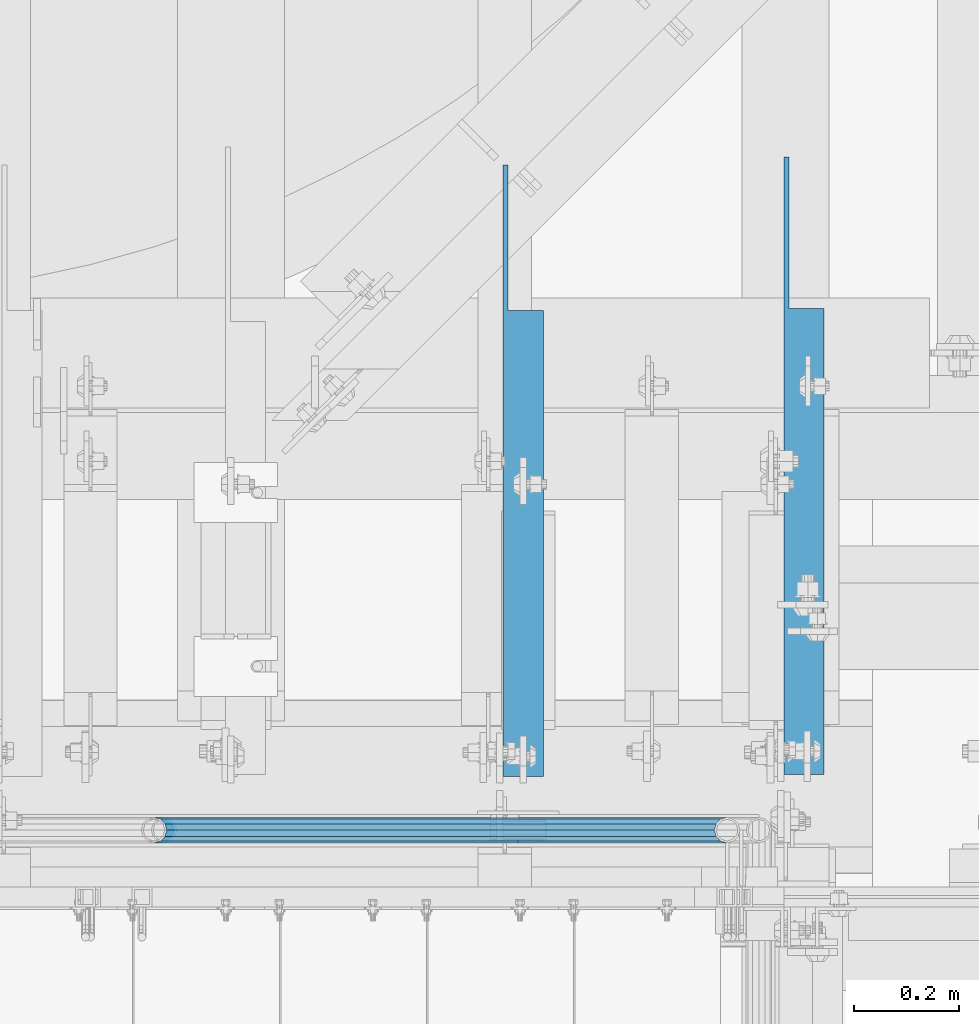
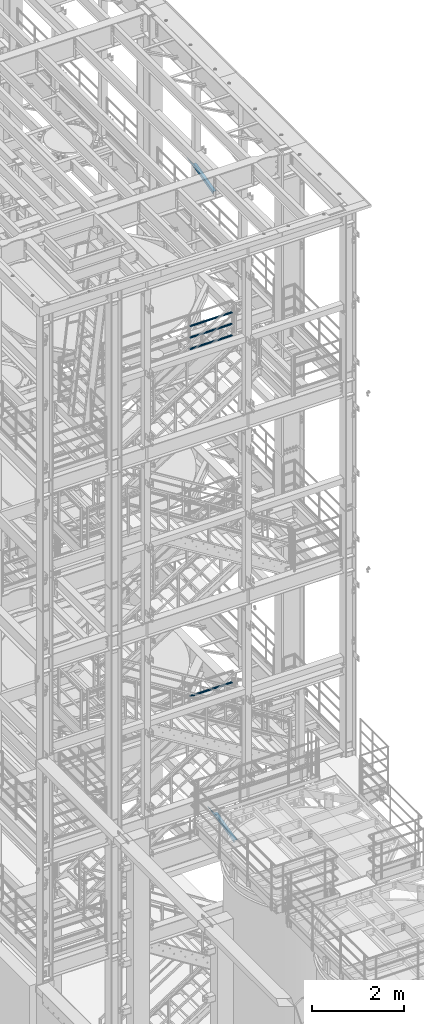
# One storey, part 987 of 1876: 6 beams, 4 elements without a shape of their own.
"""IFC2X3 building model written with IfcOpenShell, lengths in millimetres."""

from ifc_helpers import new_model, si_unit, frame, origin_with_axes, place, context, subcontext, project, spatial, faceted_brep, material, type_object, element, aggregate, save


model = new_model("IFC2X3")

# Units and contexts
model_context = context("Model", 3, precision=1e-05, world=origin_with_axes())
body_context = subcontext(model_context, "Body", "Model", "MODEL_VIEW")
ifc_project = project(units=[si_unit("LENGTHUNIT", "METRE", prefix="MILLI"), si_unit("AREAUNIT", "SQUARE_METRE"), si_unit("VOLUMEUNIT", "CUBIC_METRE"), si_unit("MASSUNIT", "GRAM", prefix="KILO"), si_unit("TIMEUNIT", "SECOND"), si_unit("PLANEANGLEUNIT", "RADIAN"), si_unit("SOLIDANGLEUNIT", "STERADIAN"), si_unit("THERMODYNAMICTEMPERATUREUNIT", "DEGREE_CELSIUS"), si_unit("LUMINOUSINTENSITYUNIT", "LUMEN")], contexts=[model_context])

# Site, building, storey
site_placement = place(None, origin_with_axes())
site = spatial("IfcSite", under=ifc_project, at=site_placement, CompositionType="ELEMENT")
building_placement = place(site_placement, origin_with_axes())
building = spatial("IfcBuilding", under=site, at=building_placement, Name="Undefined", CompositionType="ELEMENT")
storey_placement = place(building_placement, origin_with_axes())
storey = spatial("IfcBuildingStorey", under=building, at=storey_placement, Name="Undefined", CompositionType="ELEMENT", Elevation=0.0)

# Assembly, beam
assembly_1_placement = place(storey_placement, origin_with_axes())
assembly_1 = element("IfcElementAssembly", 1, at=assembly_1_placement, inside=storey, Name="RAIL", AssemblyPlace="NOTDEFINED", PredefinedType="RIGID_FRAME")
ifc_material_1 = material()
beam_type_1 = type_object("IfcBeamType", Name="PIPE1-1/2SCH40", PredefinedType="NOTDEFINED")
beam_1_placement = place(assembly_1_placement, frame((5048.24999996468, -4654.55000114554, 8924.925), z_axis=(0.0, 0.0, -1.0), x_axis=(1.0, 0.0, 0.0)))
beam_1 = element("IfcBeam", 2, at=beam_1_placement, type_object=beam_type_1, material=ifc_material_1, Name="RAIL", ObjectType="PIPE1-1/2SCH40", context=body_context, shape_type="Brep", body=[
    faceted_brep([(0.0, 24.1299999999992, 0.0), (12.0650000000064, 20.8971929933177, -12.0649999999987), (12.0650000000064, 20.8971929933177, 12.0649999999987), (12.0650000000064, -20.8971929933177, 12.0649999999987), (12.0650000000064, -20.8971929933177, -12.0649999999987), (0.0, -24.1299999999992, 0.0), (20.8971929933249, -12.0650000000005, 20.8971929933177), (20.8971929933249, -12.0650000000005, 15.8661214311796), (15.2545715621445, -17.7076214311801, 10.2235000000001), (12.5151929933249, -20.4470000000001, 0.0), (15.2545715621445, -17.7076214311801, -10.2235000000001), (20.8971929933249, -12.0650000000005, -15.8661214311796), (20.8971929933249, -12.0650000000005, -20.8971929933177), (24.1300000000063, 0.0, -20.4470000000001), (24.1300000000063, 0.0, -24.130000000001), (21.3906214311868, -10.2235000000001, -17.7076214311819), (21.3906214311868, 10.2235000000001, -17.7076214311819), (20.8971929933249, 12.0650000000005, -15.8661214311796), (20.8971929933249, 12.0650000000005, -20.8971929933177), (15.2545715621445, 17.7076214311801, -10.2235000000001), (12.5151929933249, 20.4470000000001, 0.0), (15.2545715621445, 17.7076214311801, 10.2235000000001), (20.8971929933249, 12.0650000000005, 15.8661214311796), (20.8971929933249, 12.0650000000005, 20.8971929933177), (21.3906214311868, 10.2235000000001, 17.7076214311819), (24.1300000000064, 0.0, 20.4470000000001), (24.1300000000064, 0.0, 24.130000000001), (21.3906214311868, -10.2235000000001, 17.7076214311819), (1089.02499998822, 24.1300000000001, 0.0), (1076.95999998821, 20.8971929933186, -12.0650000000005), (1068.12780699489, 12.0649999999996, -20.8971929933177), (1089.02499998821, -24.1299999999865, 0.0), (1076.95999998821, -20.8971929933186, -12.0650000000005), (1076.95999998821, -20.8971929933186, 12.0650000000005), (1068.12780699489, -12.0649999999996, 20.8971929933177), (1068.12780699489, -12.0649999999996, -20.8971929933177), (1064.89499998821, 0.0, -24.1299999999992), (1067.63437855703, 10.2235000000001, -17.7076214311801), (1064.89499998821, 0.0, -20.4470000000001), (1068.12780699489, 12.0650000000132, -15.8661214311669), (1068.12780699489, -12.064999999986, -15.8661214311942), (1067.63437855703, -10.2235000000001, -17.7076214311801), (1073.77042842609, -17.7076214311801, -10.2235000000001), (1076.50980699491, -20.4470000000001, 0.0), (1073.77042842609, -17.7076214311801, 10.2235000000001), (1068.12780699489, -12.064999999986, 15.8661214311942), (1067.63437855703, -10.2235000000001, 17.7076214311801), (1064.89499998821, 0.0, 20.4470000000001), (1064.89499998821, 0.0, 24.1299999999992), (1068.12780699489, 12.0649999999996, 20.8971929933177), (1076.95999998821, 20.8971929933186, 12.0650000000005), (1068.12780699489, 12.0650000000132, 15.8661214311669), (1073.77042842606, 17.7076214311801, 10.2235000000001), (1076.50980699488, 20.4470000000001, 0.0), (1073.77042842606, 17.7076214311801, -10.2235000000001), (1067.63437855703, 10.2235000000001, 17.7076214311801)], [[[0, 1, 2]], [[3, 4, 5]], [[6, 7, 8, 9, 10, 11, 12, 4, 3]], [[13, 14, 12, 11, 15]], [[16, 17, 18, 14, 13]], [[2, 1, 18, 17, 19, 20, 21, 22, 23]], [[23, 22, 24, 25, 26]], [[26, 25, 27, 7, 6]], [[1, 0, 28, 29]], [[18, 1, 29, 30]], [[31, 32, 33]], [[6, 3, 33, 34]], [[3, 5, 31, 33]], [[5, 4, 32, 31]], [[4, 12, 35, 32]], [[12, 14, 36, 35]], [[14, 18, 30, 36]], [[37, 38, 36, 30, 39]], [[40, 35, 36, 38, 41]], [[33, 32, 35, 40, 42, 43, 44, 45, 34]], [[34, 45, 46, 47, 48]], [[26, 6, 34, 48]], [[2, 23, 49, 50]], [[23, 26, 48, 49]], [[0, 2, 50, 28]], [[28, 50, 29]], [[49, 51, 52, 53, 54, 39, 30, 29, 50]], [[48, 47, 55, 51, 49]], [[25, 24, 55, 47]], [[55, 24, 22, 21, 52, 51]], [[21, 20, 53, 52]], [[20, 19, 54, 53]], [[19, 17, 16, 37, 39, 54]], [[16, 13, 38, 37]], [[13, 15, 41, 38]], [[41, 15, 11, 10, 42, 40]], [[10, 9, 43, 42]], [[9, 8, 44, 43]], [[8, 7, 27, 46, 45, 44]], [[27, 25, 47, 46]]]),
])
aggregate(assembly_1, [beam_1])

# Assembly, beams
assembly_2_placement = place(storey_placement, origin_with_axes())
assembly_2 = element("IfcElementAssembly", 3, at=assembly_2_placement, inside=storey, Name="RAIL", AssemblyPlace="NOTDEFINED", PredefinedType="RIGID_FRAME")
beam_2_placement = place(assembly_2_placement, frame((6137.27499995291, -4654.55000114554, 18145.125), z_axis=(0.0, 0.0, 1.0), x_axis=(-1.0, 0.0, 0.0)))
beam_2 = element("IfcBeam", 4, at=beam_2_placement, type_object=beam_type_1, material=ifc_material_1, Name="RAIL", ObjectType="PIPE1-1/2SCH40", context=body_context, shape_type="Brep", body=[
    faceted_brep([(1068.12780699489, -12.0649999999996, 20.8971929933177), (1068.12780699489, -12.064999999986, 15.8661214311942), (1067.63437855703, -10.2235000000001, 17.7076214311801), (1064.89499998821, 0.0, 20.4470000000001), (1064.89499998821, 0.0, 24.1299999999992), (1067.63437855703, 10.2235000000001, 17.7076214311801), (1068.12780699489, 12.0650000000132, 15.8661214311669), (1068.12780699489, 12.0649999999996, 20.8971929933177), (1089.02499998822, 24.1300000000001, 0.0), (1076.95999998821, 20.8971929933186, 12.0650000000005), (1076.95999998821, 20.8971929933186, -12.0650000000005), (1073.77042842606, 17.7076214311801, 10.2235000000001), (1076.50980699488, 20.4470000000001, 0.0), (1073.77042842606, 17.7076214311801, -10.2235000000001), (1068.12780699489, 12.0650000000132, -15.8661214311669), (1068.12780699489, 12.0649999999996, -20.8971929933177), (1067.63437855703, 10.2235000000001, -17.7076214311801), (1064.89499998821, 0.0, -20.4470000000001), (1064.89499998821, 0.0, -24.1299999999992), (1068.12780699489, -12.064999999986, -15.8661214311942), (1068.12780699489, -12.0649999999996, -20.8971929933177), (1067.63437855703, -10.2235000000001, -17.7076214311801), (1089.02499998821, -24.1299999999865, 0.0), (1076.95999998821, -20.8971929933186, -12.0650000000005), (1076.95999998821, -20.8971929933186, 12.0650000000005), (1073.77042842609, -17.7076214311801, -10.2235000000001), (1076.50980699491, -20.4470000000001, 0.0), (1073.77042842609, -17.7076214311801, 10.2235000000001), (12.0650000000064, -20.8971929933177, -12.0649999999987), (20.8971929933249, -12.0650000000005, -20.8971929933177), (0.0, 24.1299999999992, 0.0), (12.0650000000064, 20.8971929933177, -12.0649999999987), (12.0650000000064, 20.8971929933177, 12.0649999999987), (20.8971929933249, 12.0650000000005, 20.8971929933177), (24.1300000000064, 0.0, 24.130000000001), (20.8971929933249, 12.0650000000005, -20.8971929933177), (24.1300000000063, 0.0, -24.130000000001), (24.1300000000063, 0.0, -20.4470000000001), (20.8971929933249, -12.0650000000005, -15.8661214311796), (21.3906214311868, -10.2235000000001, -17.7076214311819), (21.3906214311868, 10.2235000000001, -17.7076214311819), (20.8971929933249, 12.0650000000005, -15.8661214311796), (15.2545715621445, 17.7076214311801, -10.2235000000001), (12.5151929933249, 20.4470000000001, 0.0), (15.2545715621445, 17.7076214311801, 10.2235000000001), (20.8971929933249, 12.0650000000005, 15.8661214311796), (21.3906214311868, 10.2235000000001, 17.7076214311819), (24.1300000000064, 0.0, 20.4470000000001), (21.3906214311868, -10.2235000000001, 17.7076214311819), (20.8971929933249, -12.0650000000005, 15.8661214311796), (20.8971929933249, -12.0650000000005, 20.8971929933177), (12.0650000000064, -20.8971929933177, 12.0649999999987), (0.0, -24.1299999999992, 0.0), (15.2545715621445, -17.7076214311801, 10.2235000000001), (12.5151929933249, -20.4470000000001, 0.0), (15.2545715621445, -17.7076214311801, -10.2235000000001)], [[[0, 1, 2, 3, 4]], [[4, 3, 5, 6, 7]], [[8, 9, 10]], [[7, 6, 11, 12, 13, 14, 15, 10, 9]], [[16, 17, 18, 15, 14]], [[19, 20, 18, 17, 21]], [[22, 23, 24]], [[24, 23, 20, 19, 25, 26, 27, 1, 0]], [[28, 29, 20, 23]], [[30, 31, 32]], [[33, 34, 4, 7]], [[32, 33, 7, 9]], [[30, 32, 9, 8]], [[31, 30, 8, 10]], [[35, 31, 10, 15]], [[36, 35, 15, 18]], [[29, 36, 18, 20]], [[37, 36, 29, 38, 39]], [[40, 41, 35, 36, 37]], [[32, 31, 35, 41, 42, 43, 44, 45, 33]], [[33, 45, 46, 47, 34]], [[34, 47, 48, 49, 50]], [[34, 50, 0, 4]], [[50, 51, 24, 0]], [[51, 52, 22, 24]], [[52, 28, 23, 22]], [[51, 28, 52]], [[50, 49, 53, 54, 55, 38, 29, 28, 51]], [[55, 54, 26, 25]], [[21, 39, 38, 55, 25, 19]], [[37, 39, 21, 17]], [[40, 37, 17, 16]], [[42, 41, 40, 16, 14, 13]], [[43, 42, 13, 12]], [[44, 43, 12, 11]], [[5, 46, 45, 44, 11, 6]], [[47, 46, 5, 3]], [[48, 47, 3, 2]], [[53, 49, 48, 2, 1, 27]], [[54, 53, 27, 26]]]),
])
beam_3_placement = place(assembly_2_placement, frame((5048.24999996468, -4654.55000114554, 18449.925), z_axis=(0.0, 0.0, -1.0), x_axis=(1.0, 0.0, 0.0)))
beam_3 = element("IfcBeam", 5, at=beam_3_placement, type_object=beam_type_1, material=ifc_material_1, Name="RAIL", ObjectType="PIPE1-1/2SCH40", context=body_context, shape_type="Brep", body=[
    faceted_brep([(0.0, 24.1299999999992, 0.0), (12.0650000000064, 20.8971929933177, -12.0649999999987), (12.0650000000064, 20.8971929933177, 12.0649999999987), (12.0650000000064, -20.8971929933177, 12.0649999999987), (12.0650000000064, -20.8971929933177, -12.0649999999987), (0.0, -24.1299999999992, 0.0), (20.8971929933249, -12.0650000000005, 20.8971929933177), (20.8971929933249, -12.0650000000005, 15.8661214311796), (15.2545715621445, -17.7076214311801, 10.2235000000001), (12.5151929933249, -20.4470000000001, 0.0), (15.2545715621445, -17.7076214311801, -10.2235000000001), (20.8971929933249, -12.0650000000005, -15.8661214311796), (20.8971929933249, -12.0650000000005, -20.8971929933177), (24.1300000000063, 0.0, -20.4470000000001), (24.1300000000063, 0.0, -24.130000000001), (21.3906214311868, -10.2235000000001, -17.7076214311819), (21.3906214311868, 10.2235000000001, -17.7076214311819), (20.8971929933249, 12.0650000000005, -15.8661214311796), (20.8971929933249, 12.0650000000005, -20.8971929933177), (15.2545715621445, 17.7076214311801, -10.2235000000001), (12.5151929933249, 20.4470000000001, 0.0), (15.2545715621445, 17.7076214311801, 10.2235000000001), (20.8971929933249, 12.0650000000005, 15.8661214311796), (20.8971929933249, 12.0650000000005, 20.8971929933177), (21.3906214311868, 10.2235000000001, 17.7076214311819), (24.1300000000064, 0.0, 20.4470000000001), (24.1300000000064, 0.0, 24.130000000001), (21.3906214311868, -10.2235000000001, 17.7076214311819), (1089.02499998822, 24.1300000000001, 0.0), (1076.95999998821, 20.8971929933186, -12.0650000000005), (1068.12780699489, 12.0649999999996, -20.8971929933177), (1089.02499998821, -24.1299999999865, 0.0), (1076.95999998821, -20.8971929933186, -12.0650000000005), (1076.95999998821, -20.8971929933186, 12.0650000000005), (1068.12780699489, -12.0649999999996, 20.8971929933177), (1068.12780699489, -12.0649999999996, -20.8971929933177), (1064.89499998821, 0.0, -24.1299999999992), (1067.63437855703, 10.2235000000001, -17.7076214311801), (1064.89499998821, 0.0, -20.4470000000001), (1068.12780699489, 12.0650000000132, -15.8661214311669), (1068.12780699489, -12.064999999986, -15.8661214311942), (1067.63437855703, -10.2235000000001, -17.7076214311801), (1073.77042842609, -17.7076214311801, -10.2235000000001), (1076.50980699491, -20.4470000000001, 0.0), (1073.77042842609, -17.7076214311801, 10.2235000000001), (1068.12780699489, -12.064999999986, 15.8661214311942), (1067.63437855703, -10.2235000000001, 17.7076214311801), (1064.89499998821, 0.0, 20.4470000000001), (1064.89499998821, 0.0, 24.1299999999992), (1068.12780699489, 12.0649999999996, 20.8971929933177), (1076.95999998821, 20.8971929933186, 12.0650000000005), (1068.12780699489, 12.0650000000132, 15.8661214311669), (1073.77042842606, 17.7076214311801, 10.2235000000001), (1076.50980699488, 20.4470000000001, 0.0), (1073.77042842606, 17.7076214311801, -10.2235000000001), (1067.63437855703, 10.2235000000001, 17.7076214311801)], [[[0, 1, 2]], [[3, 4, 5]], [[6, 7, 8, 9, 10, 11, 12, 4, 3]], [[13, 14, 12, 11, 15]], [[16, 17, 18, 14, 13]], [[2, 1, 18, 17, 19, 20, 21, 22, 23]], [[23, 22, 24, 25, 26]], [[26, 25, 27, 7, 6]], [[1, 0, 28, 29]], [[18, 1, 29, 30]], [[31, 32, 33]], [[6, 3, 33, 34]], [[3, 5, 31, 33]], [[5, 4, 32, 31]], [[4, 12, 35, 32]], [[12, 14, 36, 35]], [[14, 18, 30, 36]], [[37, 38, 36, 30, 39]], [[40, 35, 36, 38, 41]], [[33, 32, 35, 40, 42, 43, 44, 45, 34]], [[34, 45, 46, 47, 48]], [[26, 6, 34, 48]], [[2, 23, 49, 50]], [[23, 26, 48, 49]], [[0, 2, 50, 28]], [[28, 50, 29]], [[49, 51, 52, 53, 54, 39, 30, 29, 50]], [[48, 47, 55, 51, 49]], [[25, 24, 55, 47]], [[55, 24, 22, 21, 52, 51]], [[21, 20, 53, 52]], [[20, 19, 54, 53]], [[19, 17, 16, 37, 39, 54]], [[16, 13, 38, 37]], [[13, 15, 41, 38]], [[41, 15, 11, 10, 42, 40]], [[10, 9, 43, 42]], [[9, 8, 44, 43]], [[8, 7, 27, 46, 45, 44]], [[27, 25, 47, 46]]]),
])
beam_4_placement = place(assembly_2_placement, frame((5048.24999996468, -4654.55000114554, 18754.725), z_axis=(0.0, 0.0, -1.0), x_axis=(1.0, 0.0, 0.0)))
beam_4 = element("IfcBeam", 6, at=beam_4_placement, type_object=beam_type_1, material=ifc_material_1, Name="RAIL", ObjectType="PIPE1-1/2SCH40", context=body_context, shape_type="Brep", body=[
    faceted_brep([(0.0, 24.1299999999992, 0.0), (12.0650000000064, 20.8971929933177, -12.0649999999987), (12.0650000000064, 20.8971929933177, 12.0649999999987), (12.0650000000064, -20.8971929933177, 12.0649999999987), (12.0650000000064, -20.8971929933177, -12.0649999999987), (0.0, -24.1299999999992, 0.0), (20.8971929933249, -12.0650000000005, 20.8971929933177), (20.8971929933249, -12.0650000000005, 15.8661214311796), (15.2545715621445, -17.7076214311801, 10.2235000000001), (12.5151929933249, -20.4470000000001, 0.0), (15.2545715621445, -17.7076214311801, -10.2235000000001), (20.8971929933249, -12.0650000000005, -15.8661214311796), (20.8971929933249, -12.0650000000005, -20.8971929933177), (24.1300000000063, 0.0, -20.4470000000001), (24.1300000000063, 0.0, -24.130000000001), (21.3906214311868, -10.2235000000001, -17.7076214311819), (21.3906214311868, 10.2235000000001, -17.7076214311819), (20.8971929933249, 12.0650000000005, -15.8661214311796), (20.8971929933249, 12.0650000000005, -20.8971929933177), (15.2545715621445, 17.7076214311801, -10.2235000000001), (12.5151929933249, 20.4470000000001, 0.0), (15.2545715621445, 17.7076214311801, 10.2235000000001), (20.8971929933249, 12.0650000000005, 15.8661214311796), (20.8971929933249, 12.0650000000005, 20.8971929933177), (21.3906214311868, 10.2235000000001, 17.7076214311819), (24.1300000000064, 0.0, 20.4470000000001), (24.1300000000064, 0.0, 24.130000000001), (21.3906214311868, -10.2235000000001, 17.7076214311819), (1089.02499998822, 24.1300000000001, 0.0), (1076.95999998821, 20.8971929933186, -12.0650000000005), (1068.12780699489, 12.0649999999996, -20.8971929933177), (1089.02499998821, -24.1299999999865, 0.0), (1076.95999998821, -20.8971929933186, -12.0650000000005), (1076.95999998821, -20.8971929933186, 12.0650000000005), (1068.12780699489, -12.0649999999996, 20.8971929933177), (1068.12780699489, -12.0649999999996, -20.8971929933177), (1064.89499998821, 0.0, -24.1299999999992), (1067.63437855703, 10.2235000000001, -17.7076214311801), (1064.89499998821, 0.0, -20.4470000000001), (1068.12780699489, 12.0650000000132, -15.8661214311669), (1068.12780699489, -12.064999999986, -15.8661214311942), (1067.63437855703, -10.2235000000001, -17.7076214311801), (1073.77042842609, -17.7076214311801, -10.2235000000001), (1076.50980699491, -20.4470000000001, 0.0), (1073.77042842609, -17.7076214311801, 10.2235000000001), (1068.12780699489, -12.064999999986, 15.8661214311942), (1067.63437855703, -10.2235000000001, 17.7076214311801), (1064.89499998821, 0.0, 20.4470000000001), (1064.89499998821, 0.0, 24.1299999999992), (1068.12780699489, 12.0649999999996, 20.8971929933177), (1076.95999998821, 20.8971929933186, 12.0650000000005), (1068.12780699489, 12.0650000000132, 15.8661214311669), (1073.77042842606, 17.7076214311801, 10.2235000000001), (1076.50980699488, 20.4470000000001, 0.0), (1073.77042842606, 17.7076214311801, -10.2235000000001), (1067.63437855703, 10.2235000000001, 17.7076214311801)], [[[0, 1, 2]], [[3, 4, 5]], [[6, 7, 8, 9, 10, 11, 12, 4, 3]], [[13, 14, 12, 11, 15]], [[16, 17, 18, 14, 13]], [[2, 1, 18, 17, 19, 20, 21, 22, 23]], [[23, 22, 24, 25, 26]], [[26, 25, 27, 7, 6]], [[1, 0, 28, 29]], [[18, 1, 29, 30]], [[31, 32, 33]], [[6, 3, 33, 34]], [[3, 5, 31, 33]], [[5, 4, 32, 31]], [[4, 12, 35, 32]], [[12, 14, 36, 35]], [[14, 18, 30, 36]], [[37, 38, 36, 30, 39]], [[40, 35, 36, 38, 41]], [[33, 32, 35, 40, 42, 43, 44, 45, 34]], [[34, 45, 46, 47, 48]], [[26, 6, 34, 48]], [[2, 23, 49, 50]], [[23, 26, 48, 49]], [[0, 2, 50, 28]], [[28, 50, 29]], [[49, 51, 52, 53, 54, 39, 30, 29, 50]], [[48, 47, 55, 51, 49]], [[25, 24, 55, 47]], [[55, 24, 22, 21, 52, 51]], [[21, 20, 53, 52]], [[20, 19, 54, 53]], [[19, 17, 16, 37, 39, 54]], [[16, 13, 38, 37]], [[13, 15, 41, 38]], [[41, 15, 11, 10, 42, 40]], [[10, 9, 43, 42]], [[9, 8, 44, 43]], [[8, 7, 27, 46, 45, 44]], [[27, 25, 47, 46]]]),
])
aggregate(assembly_2, [beam_2, beam_3, beam_4])

# Assembly, beam
assembly_3_placement = place(storey_placement, origin_with_axes())
assembly_3 = element("IfcElementAssembly", 7, at=assembly_3_placement, inside=storey, AssemblyPlace="NOTDEFINED", PredefinedType="RIGID_FRAME")
ifc_material_2 = material(Name="STEEL/A36")
beam_type_2 = type_object("IfcBeamType", Name="L3X3X3/8", PredefinedType="NOTDEFINED")
beam_5_placement = place(assembly_3_placement, frame((5749.92500019074, -4562.78281844778, 21997.5317219592), z_axis=(1.0, 0.0, 0.0), x_axis=(0.0, 0.97029600569138, 0.241920774923019)))
beam_5 = element("IfcBeam", 8, at=beam_5_placement, type_object=beam_type_2, material=ifc_material_2, ObjectType="L3X3X3/8", context=body_context, shape_type="Brep", body=[
    faceted_brep([(20.4512332895073, 38.1000000000495, -38.0999999999999), (20.4512332895073, 38.1000000000495, 38.0999999999999), (892.440924395522, 38.0999999997366, 38.0999999999999), (892.440924395522, 38.0999999997366, -38.0999999999999), (20.4512332895037, 28.5750000000371, 38.0999999999999), (930.643800759319, 28.5749999997061, 38.0999999999999), (20.4512332895037, 28.5750000000371, -28.575), (930.643800759319, 28.5749999997061, -28.575), (20.4512332894728, -38.1000000000604, -28.575), (1198.0639353059, -38.1000000004824, -28.575), (20.4512332894728, -38.1000000000604, -38.0999999999999), (1198.0639353059, -38.1000000004824, -38.0999999999999)], [[[0, 1, 2, 3]], [[1, 4, 5, 2]], [[4, 6, 7, 5]], [[6, 8, 9, 7]], [[8, 10, 11, 9]], [[10, 0, 3, 11]], [[5, 7, 9, 11, 3, 2]], [[10, 8, 6, 4, 1, 0]]]),
])
aggregate(assembly_3, [beam_5])

assembly_4_placement = place(storey_placement, origin_with_axes())
assembly_4 = element("IfcElementAssembly", 9, at=assembly_4_placement, inside=storey, AssemblyPlace="NOTDEFINED", PredefinedType="RIGID_FRAME")
beam_6_placement = place(assembly_4_placement, frame((6283.325, -4563.17888153773, 4573.03522166451), z_axis=(1.0, 0.0, 0.0), x_axis=(0.0, 0.972828834357876, 0.231525504085181)))
beam_6 = element("IfcBeam", 10, at=beam_6_placement, type_object=beam_type_2, material=ifc_material_2, ObjectType="L3X3X3/8", context=body_context, shape_type="Brep", body=[
    faceted_brep([(23.708753528113, 38.0999999999831, -38.1000000000004), (23.708753528113, 38.0999999999831, 38.1000000000004), (891.370480163695, 38.0999999997657, 38.1000000000004), (891.370480163695, 38.0999999997657, -38.1000000000004), (23.7856351179548, 28.5749999999862, 38.1000000000004), (931.392829683586, 28.5749999997579, 38.1000000000004), (23.7856351179548, 28.5749999999862, -28.5749999999998), (931.392829683586, 28.5749999997579, -28.5749999999998), (24.3238062468486, -38.0999999999931, -28.5749999999998), (1211.54927632283, -38.1000000002923, -28.5749999999998), (24.3238062468486, -38.0999999999931, -38.1000000000004), (1211.54927632283, -38.1000000002923, -38.1000000000004)], [[[0, 1, 2, 3]], [[1, 4, 5, 2]], [[4, 6, 7, 5]], [[6, 8, 9, 7]], [[8, 10, 11, 9]], [[10, 0, 3, 11]], [[5, 7, 9, 11, 3, 2]], [[10, 8, 6, 4, 1, 0]]]),
])
aggregate(assembly_4, [beam_6])

save(model, "model.ifc")
